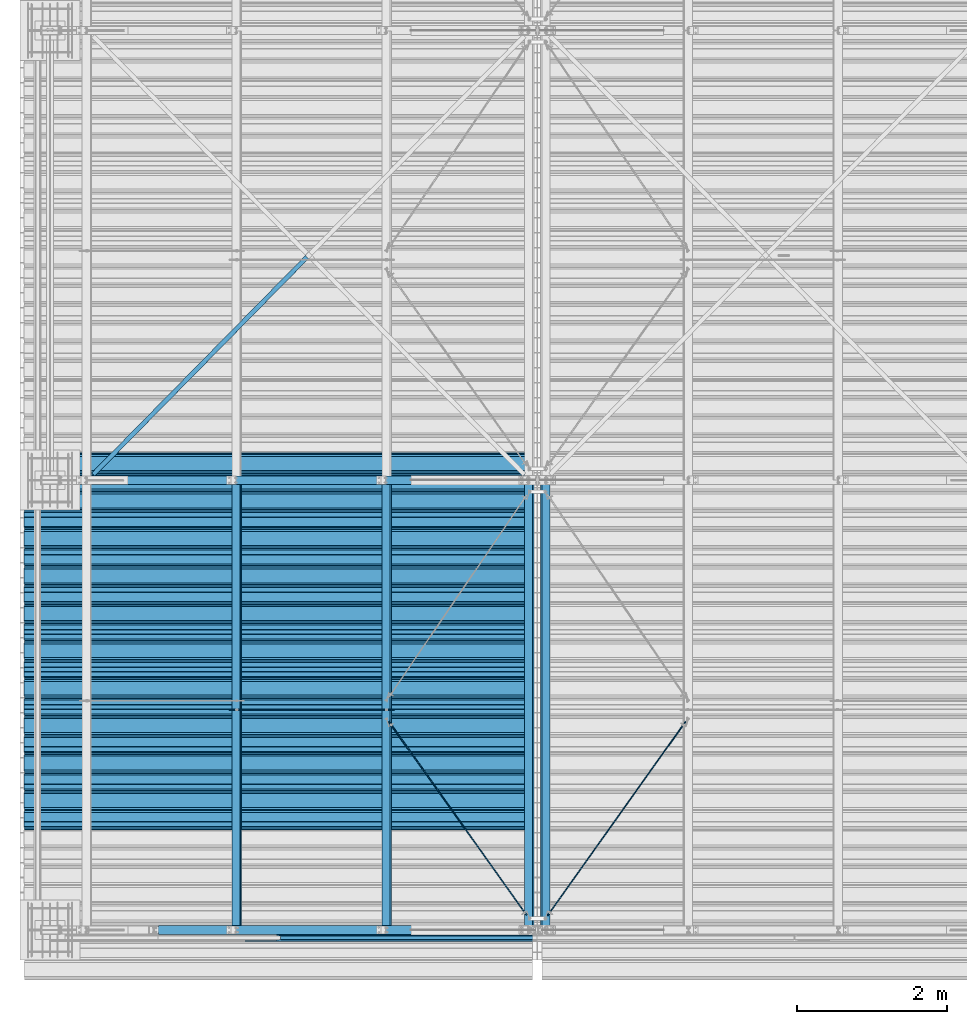
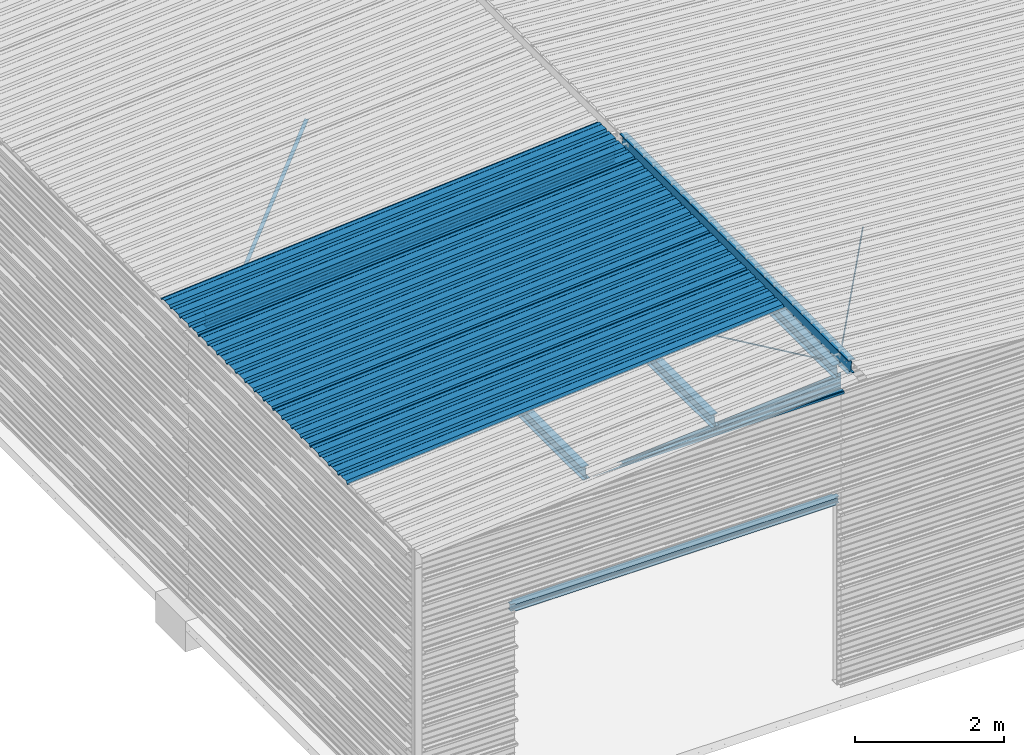
# One storey, part 6 of 70: 16 beams, 16 elements without a shape of their own.
"""IFC2X3 building model written with IfcOpenShell, lengths in millimetres."""

from ifc_helpers import new_model, si_unit, frame, origin_with_axes, origin_2d_with_axis, place, context, subcontext, project, spatial, polyline, circle, i_section, l_section, outline, extrude, boolean, clip, halfspace, material, type_object, element, aggregate, save


model = new_model("IFC2X3")

# Units and contexts
model_context = context("Model", 3, precision=1e-05, world=origin_with_axes())
body_context = subcontext(model_context, "Body", "Model", "MODEL_VIEW")
ifc_project = project(units=[si_unit("LENGTHUNIT", "METRE", prefix="MILLI"), si_unit("AREAUNIT", "SQUARE_METRE"), si_unit("VOLUMEUNIT", "CUBIC_METRE"), si_unit("MASSUNIT", "GRAM", prefix="KILO"), si_unit("TIMEUNIT", "SECOND"), si_unit("PLANEANGLEUNIT", "RADIAN"), si_unit("SOLIDANGLEUNIT", "STERADIAN"), si_unit("THERMODYNAMICTEMPERATUREUNIT", "DEGREE_CELSIUS"), si_unit("LUMINOUSINTENSITYUNIT", "LUMEN")], contexts=[model_context])

# Site, building, storey
site_placement = place(None, origin_with_axes())
site = spatial("IfcSite", under=ifc_project, at=site_placement, CompositionType="ELEMENT")
building_placement = place(site_placement, origin_with_axes())
building = spatial("IfcBuilding", under=site, at=building_placement, Name="Undefined", CompositionType="ELEMENT")
storey_placement = place(building_placement, origin_with_axes())
storey = spatial("IfcBuildingStorey", under=building, at=storey_placement, Name="Undefined", CompositionType="ELEMENT", Elevation=0.0)

# Assembly, beam
assembly_1_placement = place(storey_placement, origin_with_axes())
assembly_1 = element("IfcElementAssembly", 1, at=assembly_1_placement, inside=storey, Name="Steel Assembly", AssemblyPlace="NOTDEFINED", PredefinedType="RIGID_FRAME")
ifc_material = material(Name="STEEL/S235JR")
beam_type_1 = type_object("IfcBeamType", Name="4.40", PredefinedType="NOTDEFINED")
beam_1_placement = place(assembly_1_placement, frame((6436.39248868039, 1850.0, 5336.31760454388), z_axis=(0.0766964990376782, 0.0, -0.997054485489817), x_axis=(-0.997054485489818, 0.0, -0.0766964990376602)))
beam_1 = element("IfcBeam", 2, at=beam_1_placement, type_object=beam_type_1, material=ifc_material, ObjectType="4.40", context=body_context, shape_type="SweptSolid", body=[
    extrude(outline(polyline([(509.415161132813, 19.5000000011705), (490.584838867188, 19.5000000011705), (468.084838867188, -20.4999999988113), (406.585784912109, -20.4999999988113), (404.585784912109, -18.4999999988122), (345.414215087891, -18.4999999988122), (343.414215087891, -20.4999999988113), (281.915161132813, -20.4999999988113), (259.415161132813, 19.5000000011705), (240.584854125977, 19.5000000011705), (218.084854125977, -20.4999999988113), (156.585784912109, -20.4999999988113), (154.585784912109, -18.4999999988122), (95.4142150878906, -18.4999999988122), (93.4142150878906, -20.4999999988113), (31.9151515960693, -20.4999999988113), (9.41515254974365, 19.5000000011705), (-9.41515254974365, 19.5000000011705), (-31.9151515960693, -20.4999999988113), (-93.4142150878906, -20.4999999988113), (-95.4142150878906, -18.4999999988122), (-154.585784912109, -18.4999999988122), (-156.585784912109, -20.4999999988113), (-218.084854125977, -20.4999999988113), (-240.584854125977, 19.5000000011705), (-259.415161132813, 19.5000000011705), (-281.915161132813, -20.4999999988113), (-343.414215087891, -20.4999999988113), (-345.414215087891, -18.4999999988122), (-404.585784912109, -18.4999999988122), (-406.585784912109, -20.4999999988113), (-468.084838867188, -20.4999999988113), (-490.584838867188, 19.5000000011705), (-509.415161132813, 19.5000000011705), (-516.482360839844, 6.9361057293263), (-517.353942871094, 7.42636680720625), (-510.0, 20.5000000011705), (-490.0, 20.5000000011705), (-467.5, -19.4999999988122), (-407.0, -19.4999999988122), (-405.0, -17.4999999988131), (-345.0, -17.4999999988131), (-343.0, -19.4999999988122), (-282.5, -19.4999999988122), (-260.0, 20.5000000011705), (-240.0, 20.5000000011705), (-217.5, -19.4999999988122), (-157.0, -19.4999999988122), (-155.0, -17.4999999988131), (-95.0, -17.4999999988131), (-93.0, -19.4999999988122), (-32.5, -19.4999999988122), (-10.0, 20.5000000011705), (10.0, 20.5000000011705), (32.5, -19.4999999988122), (93.0, -19.4999999988122), (95.0, -17.4999999988131), (155.0, -17.4999999988131), (157.0, -19.4999999988122), (217.5, -19.4999999988122), (240.0, 20.5000000011705), (260.0, 20.5000000011705), (282.5, -19.4999999988122), (343.0, -19.4999999988122), (345.0, -17.4999999988131), (405.0, -17.4999999988131), (407.0, -19.4999999988122), (467.5, -19.4999999988122), (490.0, 20.5000000011705), (510.0, 20.5000000011705), (517.353942871094, 7.42636680720625), (516.482360839844, 6.9361057293263), (509.415161132813, 19.5000000011705)])), frame((6799.99999999733, 2.8421709430404e-14, 0.0), z_axis=(-1.0, 0.0, 0.0), x_axis=(0.0, -1.0, 0.0)), (0.0, 0.0, 1.0), 6800.0),
])
aggregate(assembly_1, [beam_1])

assembly_2_placement = place(storey_placement, origin_with_axes())
assembly_2 = element("IfcElementAssembly", 3, at=assembly_2_placement, inside=storey, Name="Steel Assembly", AssemblyPlace="NOTDEFINED", PredefinedType="RIGID_FRAME")
beam_2_placement = place(assembly_2_placement, frame((6436.39248868039, 2850.0, 5336.31760454388), z_axis=(0.0766964990376782, 0.0, -0.997054485489817), x_axis=(-0.997054485489818, 0.0, -0.0766964990376602)))
beam_2 = element("IfcBeam", 4, at=beam_2_placement, type_object=beam_type_1, material=ifc_material, ObjectType="4.40", context=body_context, shape_type="SweptSolid", body=[
    extrude(outline(polyline([(509.415161132813, 19.5000000011705), (490.584838867188, 19.5000000011705), (468.084838867188, -20.4999999988113), (406.585784912109, -20.4999999988113), (404.585784912109, -18.4999999988122), (345.414215087891, -18.4999999988122), (343.414215087891, -20.4999999988113), (281.915161132813, -20.4999999988113), (259.415161132813, 19.5000000011705), (240.584854125977, 19.5000000011705), (218.084854125977, -20.4999999988113), (156.585784912109, -20.4999999988113), (154.585784912109, -18.4999999988122), (95.4142150878906, -18.4999999988122), (93.4142150878906, -20.4999999988113), (31.9151515960693, -20.4999999988113), (9.41515254974365, 19.5000000011705), (-9.41515254974365, 19.5000000011705), (-31.9151515960693, -20.4999999988113), (-93.4142150878906, -20.4999999988113), (-95.4142150878906, -18.4999999988122), (-154.585784912109, -18.4999999988122), (-156.585784912109, -20.4999999988113), (-218.084854125977, -20.4999999988113), (-240.584854125977, 19.5000000011705), (-259.415161132813, 19.5000000011705), (-281.915161132813, -20.4999999988113), (-343.414215087891, -20.4999999988113), (-345.414215087891, -18.4999999988122), (-404.585784912109, -18.4999999988122), (-406.585784912109, -20.4999999988113), (-468.084838867188, -20.4999999988113), (-490.584838867188, 19.5000000011705), (-509.415161132813, 19.5000000011705), (-516.482360839844, 6.9361057293263), (-517.353942871094, 7.42636680720625), (-510.0, 20.5000000011705), (-490.0, 20.5000000011705), (-467.5, -19.4999999988122), (-407.0, -19.4999999988122), (-405.0, -17.4999999988131), (-345.0, -17.4999999988131), (-343.0, -19.4999999988122), (-282.5, -19.4999999988122), (-260.0, 20.5000000011705), (-240.0, 20.5000000011705), (-217.5, -19.4999999988122), (-157.0, -19.4999999988122), (-155.0, -17.4999999988131), (-95.0, -17.4999999988131), (-93.0, -19.4999999988122), (-32.5, -19.4999999988122), (-10.0, 20.5000000011705), (10.0, 20.5000000011705), (32.5, -19.4999999988122), (93.0, -19.4999999988122), (95.0, -17.4999999988131), (155.0, -17.4999999988131), (157.0, -19.4999999988122), (217.5, -19.4999999988122), (240.0, 20.5000000011705), (260.0, 20.5000000011705), (282.5, -19.4999999988122), (343.0, -19.4999999988122), (345.0, -17.4999999988131), (405.0, -17.4999999988131), (407.0, -19.4999999988122), (467.5, -19.4999999988122), (490.0, 20.5000000011705), (510.0, 20.5000000011705), (517.353942871094, 7.42636680720625), (516.482360839844, 6.9361057293263), (509.415161132813, 19.5000000011705)])), frame((6799.99999999733, 2.8421709430404e-14, 0.0), z_axis=(-1.0, 0.0, 0.0), x_axis=(0.0, -1.0, 0.0)), (0.0, 0.0, 1.0), 6800.0),
])
aggregate(assembly_2, [beam_2])

assembly_3_placement = place(storey_placement, origin_with_axes())
assembly_3 = element("IfcElementAssembly", 5, at=assembly_3_placement, inside=storey, Name="Steel Assembly", AssemblyPlace="NOTDEFINED", PredefinedType="RIGID_FRAME")
beam_3_placement = place(assembly_3_placement, frame((6436.39248868039, 3850.0, 5336.31760454388), z_axis=(0.0766964990376782, 0.0, -0.997054485489817), x_axis=(-0.997054485489818, 0.0, -0.0766964990376602)))
beam_3 = element("IfcBeam", 6, at=beam_3_placement, type_object=beam_type_1, material=ifc_material, ObjectType="4.40", context=body_context, shape_type="SweptSolid", body=[
    extrude(outline(polyline([(509.415161132813, 19.5000000011705), (490.584838867188, 19.5000000011705), (468.084838867188, -20.4999999988113), (406.585784912109, -20.4999999988113), (404.585784912109, -18.4999999988122), (345.414215087891, -18.4999999988122), (343.414215087891, -20.4999999988113), (281.915161132813, -20.4999999988113), (259.415161132813, 19.5000000011705), (240.584854125977, 19.5000000011705), (218.084854125977, -20.4999999988113), (156.585784912109, -20.4999999988113), (154.585784912109, -18.4999999988122), (95.4142150878906, -18.4999999988122), (93.4142150878906, -20.4999999988113), (31.9151515960693, -20.4999999988113), (9.41515254974365, 19.5000000011705), (-9.41515254974365, 19.5000000011705), (-31.9151515960693, -20.4999999988113), (-93.4142150878906, -20.4999999988113), (-95.4142150878906, -18.4999999988122), (-154.585784912109, -18.4999999988122), (-156.585784912109, -20.4999999988113), (-218.084854125977, -20.4999999988113), (-240.584854125977, 19.5000000011705), (-259.415161132813, 19.5000000011705), (-281.915161132813, -20.4999999988113), (-343.414215087891, -20.4999999988113), (-345.414215087891, -18.4999999988122), (-404.585784912109, -18.4999999988122), (-406.585784912109, -20.4999999988113), (-468.084838867188, -20.4999999988113), (-490.584838867188, 19.5000000011705), (-509.415161132813, 19.5000000011705), (-516.482360839844, 6.9361057293263), (-517.353942871094, 7.42636680720625), (-510.0, 20.5000000011705), (-490.0, 20.5000000011705), (-467.5, -19.4999999988122), (-407.0, -19.4999999988122), (-405.0, -17.4999999988131), (-345.0, -17.4999999988131), (-343.0, -19.4999999988122), (-282.5, -19.4999999988122), (-260.0, 20.5000000011705), (-240.0, 20.5000000011705), (-217.5, -19.4999999988122), (-157.0, -19.4999999988122), (-155.0, -17.4999999988131), (-95.0, -17.4999999988131), (-93.0, -19.4999999988122), (-32.5, -19.4999999988122), (-10.0, 20.5000000011705), (10.0, 20.5000000011705), (32.5, -19.4999999988122), (93.0, -19.4999999988122), (95.0, -17.4999999988131), (155.0, -17.4999999988131), (157.0, -19.4999999988122), (217.5, -19.4999999988122), (240.0, 20.5000000011705), (260.0, 20.5000000011705), (282.5, -19.4999999988122), (343.0, -19.4999999988122), (345.0, -17.4999999988131), (405.0, -17.4999999988131), (407.0, -19.4999999988122), (467.5, -19.4999999988122), (490.0, 20.5000000011705), (510.0, 20.5000000011705), (517.353942871094, 7.42636680720625), (516.482360839844, 6.9361057293263), (509.415161132813, 19.5000000011705)])), frame((6799.99999999733, 2.8421709430404e-14, 0.0), z_axis=(-1.0, 0.0, 0.0), x_axis=(0.0, -1.0, 0.0)), (0.0, 0.0, 1.0), 6800.0),
])
aggregate(assembly_3, [beam_3])

assembly_4_placement = place(storey_placement, origin_with_axes())
assembly_4 = element("IfcElementAssembly", 7, at=assembly_4_placement, inside=storey, Name="Steel Assembly", AssemblyPlace="NOTDEFINED", PredefinedType="RIGID_FRAME")
beam_4_placement = place(assembly_4_placement, frame((6436.39248868039, 4850.0, 5336.31760454388), z_axis=(0.0766964990376782, 0.0, -0.997054485489817), x_axis=(-0.997054485489818, 0.0, -0.0766964990376602)))
beam_4 = element("IfcBeam", 8, at=beam_4_placement, type_object=beam_type_1, material=ifc_material, ObjectType="4.40", context=body_context, shape_type="SweptSolid", body=[
    extrude(outline(polyline([(509.415161132813, 19.5000000011705), (490.584838867188, 19.5000000011705), (468.084838867188, -20.4999999988113), (406.585784912109, -20.4999999988113), (404.585784912109, -18.4999999988122), (345.414215087891, -18.4999999988122), (343.414215087891, -20.4999999988113), (281.915161132813, -20.4999999988113), (259.415161132813, 19.5000000011705), (240.584854125977, 19.5000000011705), (218.084854125977, -20.4999999988113), (156.585784912109, -20.4999999988113), (154.585784912109, -18.4999999988122), (95.4142150878906, -18.4999999988122), (93.4142150878906, -20.4999999988113), (31.9151515960693, -20.4999999988113), (9.41515254974365, 19.5000000011705), (-9.41515254974365, 19.5000000011705), (-31.9151515960693, -20.4999999988113), (-93.4142150878906, -20.4999999988113), (-95.4142150878906, -18.4999999988122), (-154.585784912109, -18.4999999988122), (-156.585784912109, -20.4999999988113), (-218.084854125977, -20.4999999988113), (-240.584854125977, 19.5000000011705), (-259.415161132813, 19.5000000011705), (-281.915161132813, -20.4999999988113), (-343.414215087891, -20.4999999988113), (-345.414215087891, -18.4999999988122), (-404.585784912109, -18.4999999988122), (-406.585784912109, -20.4999999988113), (-468.084838867188, -20.4999999988113), (-490.584838867188, 19.5000000011705), (-509.415161132813, 19.5000000011705), (-516.482360839844, 6.9361057293263), (-517.353942871094, 7.42636680720625), (-510.0, 20.5000000011705), (-490.0, 20.5000000011705), (-467.5, -19.4999999988122), (-407.0, -19.4999999988122), (-405.0, -17.4999999988131), (-345.0, -17.4999999988131), (-343.0, -19.4999999988122), (-282.5, -19.4999999988122), (-260.0, 20.5000000011705), (-240.0, 20.5000000011705), (-217.5, -19.4999999988122), (-157.0, -19.4999999988122), (-155.0, -17.4999999988131), (-95.0, -17.4999999988131), (-93.0, -19.4999999988122), (-32.5, -19.4999999988122), (-10.0, 20.5000000011705), (10.0, 20.5000000011705), (32.5, -19.4999999988122), (93.0, -19.4999999988122), (95.0, -17.4999999988131), (155.0, -17.4999999988131), (157.0, -19.4999999988122), (217.5, -19.4999999988122), (240.0, 20.5000000011705), (260.0, 20.5000000011705), (282.5, -19.4999999988122), (343.0, -19.4999999988122), (345.0, -17.4999999988131), (405.0, -17.4999999988131), (407.0, -19.4999999988122), (467.5, -19.4999999988122), (490.0, 20.5000000011705), (510.0, 20.5000000011705), (517.353942871094, 7.42636680720625), (516.482360839844, 6.9361057293263), (509.415161132813, 19.5000000011705)])), frame((6799.99999999733, 2.8421709430404e-14, 0.0), z_axis=(-1.0, 0.0, 0.0), x_axis=(0.0, -1.0, 0.0)), (0.0, 0.0, 1.0), 6800.0),
])
aggregate(assembly_4, [beam_4])

assembly_5_placement = place(storey_placement, origin_with_axes())
assembly_5 = element("IfcElementAssembly", 9, at=assembly_5_placement, inside=storey, Name="Steel Assembly", AssemblyPlace="NOTDEFINED", PredefinedType="RIGID_FRAME")
beam_5_placement = place(assembly_5_placement, frame((6436.39248868039, 5850.0, 5336.31760454388), z_axis=(0.0766964990376782, 0.0, -0.997054485489817), x_axis=(-0.997054485489818, 0.0, -0.0766964990376602)))
beam_5 = element("IfcBeam", 10, at=beam_5_placement, type_object=beam_type_1, material=ifc_material, ObjectType="4.40", context=body_context, shape_type="SweptSolid", body=[
    extrude(outline(polyline([(509.415161132813, 19.5000000011705), (490.584838867188, 19.5000000011705), (468.084838867188, -20.4999999988113), (406.585784912109, -20.4999999988113), (404.585784912109, -18.4999999988122), (345.414215087891, -18.4999999988122), (343.414215087891, -20.4999999988113), (281.915161132813, -20.4999999988113), (259.415161132813, 19.5000000011705), (240.584854125977, 19.5000000011705), (218.084854125977, -20.4999999988113), (156.585784912109, -20.4999999988113), (154.585784912109, -18.4999999988122), (95.4142150878906, -18.4999999988122), (93.4142150878906, -20.4999999988113), (31.9151515960693, -20.4999999988113), (9.41515254974365, 19.5000000011705), (-9.41515254974365, 19.5000000011705), (-31.9151515960693, -20.4999999988113), (-93.4142150878906, -20.4999999988113), (-95.4142150878906, -18.4999999988122), (-154.585784912109, -18.4999999988122), (-156.585784912109, -20.4999999988113), (-218.084854125977, -20.4999999988113), (-240.584854125977, 19.5000000011705), (-259.415161132813, 19.5000000011705), (-281.915161132813, -20.4999999988113), (-343.414215087891, -20.4999999988113), (-345.414215087891, -18.4999999988122), (-404.585784912109, -18.4999999988122), (-406.585784912109, -20.4999999988113), (-468.084838867188, -20.4999999988113), (-490.584838867188, 19.5000000011705), (-509.415161132813, 19.5000000011705), (-516.482360839844, 6.9361057293263), (-517.353942871094, 7.42636680720625), (-510.0, 20.5000000011705), (-490.0, 20.5000000011705), (-467.5, -19.4999999988122), (-407.0, -19.4999999988122), (-405.0, -17.4999999988131), (-345.0, -17.4999999988131), (-343.0, -19.4999999988122), (-282.5, -19.4999999988122), (-260.0, 20.5000000011705), (-240.0, 20.5000000011705), (-217.5, -19.4999999988122), (-157.0, -19.4999999988122), (-155.0, -17.4999999988131), (-95.0, -17.4999999988131), (-93.0, -19.4999999988122), (-32.5, -19.4999999988122), (-10.0, 20.5000000011705), (10.0, 20.5000000011705), (32.5, -19.4999999988122), (93.0, -19.4999999988122), (95.0, -17.4999999988131), (155.0, -17.4999999988131), (157.0, -19.4999999988122), (217.5, -19.4999999988122), (240.0, 20.5000000011705), (260.0, 20.5000000011705), (282.5, -19.4999999988122), (343.0, -19.4999999988122), (345.0, -17.4999999988131), (405.0, -17.4999999988131), (407.0, -19.4999999988122), (467.5, -19.4999999988122), (490.0, 20.5000000011705), (510.0, 20.5000000011705), (517.353942871094, 7.42636680720625), (516.482360839844, 6.9361057293263), (509.415161132813, 19.5000000011705)])), frame((6799.99999999733, 2.8421709430404e-14, 0.0), z_axis=(-1.0, 0.0, 0.0), x_axis=(0.0, -1.0, 0.0)), (0.0, 0.0, 1.0), 6800.0),
])
aggregate(assembly_5, [beam_5])

assembly_6_placement = place(storey_placement, origin_with_axes())
assembly_6 = element("IfcElementAssembly", 11, at=assembly_6_placement, inside=storey, Name="Steel Assembly", AssemblyPlace="NOTDEFINED", PredefinedType="RIGID_FRAME")
beam_type_2 = type_object("IfcBeamType", Name="400", PredefinedType="NOTDEFINED")
beam_6_placement = place(assembly_6_placement, frame((6500.0, -105.5, 5018.25), z_axis=(0.0, -1.0, 0.0), x_axis=(-1.0, 0.0, 0.0)))
beam_6 = element("IfcBeam", 12, at=beam_6_placement, type_object=beam_type_2, material=ifc_material, ObjectType="400", context=body_context, shape_type="Clipping", body=[
    clip(extrude(outline(polyline([(218.25, -24.994083404541), (214.25, -31.8999996185303), (214.25, -45.5), (199.75, -45.5), (194.25, -42.5), (188.75, -45.5), (124.25, -45.5), (114.25, -41.5), (104.25, -45.5), (24.25, -45.5), (14.25, -41.5), (4.25, -45.5), (-75.75, -45.5), (-85.75, -41.5), (-95.75, -45.5), (-160.25, -45.5), (-165.75, -42.5), (-171.25, -45.5), (-185.75, -45.5), (-185.75, -30.711540222168), (-181.75, -23.8111782073975), (-181.75, 23.311637878418), (-185.75, 30.2119998931885), (-185.75, 44.5), (-217.25, 44.5), (-217.25, 34.7999992370605), (-218.25, 34.7999992370605), (-218.25, 45.5), (-184.75, 45.5), (-184.75, 30.480884552002), (-180.75, 23.5805225372314), (-180.75, -24.0800628662109), (-184.75, -30.9804248809814), (-184.75, -44.5), (-171.504989624023, -44.5), (-165.75, -41.360912322998), (-159.995010375977, -44.5), (-95.9425811767578, -44.5), (-85.75, -40.422966003418), (-75.5574188232422, -44.5), (4.05741739273071, -44.5), (14.25, -40.422966003418), (24.4425830841064, -44.5), (104.057418823242, -44.5), (114.25, -40.422966003418), (124.442581176758, -44.5), (188.495010375977, -44.5), (194.25, -41.360912322998), (200.004989624023, -44.5), (213.25, -44.5), (213.25, -31.6313018798828), (217.25, -24.7253856658936), (217.25, 21.7253856658936), (213.25, 28.6313018798828), (213.25, 42.0), (187.25, 42.0), (187.25, 32.5499992370605), (186.25, 32.5499992370605), (186.25, 43.0), (214.25, 43.0), (214.25, 28.8999996185303), (218.25, 21.994083404541), (218.25, -24.994083404541)])), frame((6500.0, 0.0, 0.0), z_axis=(-1.0, 0.0, 0.0), x_axis=(0.0, -1.0, 0.0)), (0.0, 0.0, 1.0), 6500.0), halfspace(frame((6500.0, 418.250001003011, -45.0), z_axis=(0.0766964990376779, -0.997054485489817, 0.0), x_axis=(-0.997054485489817, -0.0766964990376779, 0.0)), False)),
])
aggregate(assembly_6, [beam_6])

assembly_7_placement = place(storey_placement, origin_with_axes())
assembly_7 = element("IfcElementAssembly", 13, at=assembly_7_placement, inside=storey, Name="Steel Assembly", AssemblyPlace="NOTDEFINED", PredefinedType="RIGID_FRAME")
beam_type_3 = type_object("IfcBeamType", Name="HEA120", PredefinedType="NOTDEFINED")
beam_7_placement = place(assembly_7_placement, frame((6499.99999986275, 0.0, 3000.00000002277), z_axis=(0.0, 0.0, -1.0), x_axis=(-1.0, 0.0, 0.0)))
beam_7 = element("IfcBeam", 14, at=beam_7_placement, type_object=beam_type_3, material=ifc_material, Name="POUTRE", ObjectType="HEA120", context=body_context, shape_type="CSG", body=[
    boolean("DIFFERENCE", boolean("DIFFERENCE", boolean("DIFFERENCE", boolean("DIFFERENCE", boolean("DIFFERENCE", boolean("DIFFERENCE", extrude(i_section(OverallWidth=120.0, OverallDepth=114.0, WebThickness=5.0, FlangeThickness=8.0, FilletRadius=12.0, at=origin_2d_with_axis()), frame((5108.49999986277, 0.0, 0.0), z_axis=(-1.0, 0.0, 0.0), x_axis=(0.0, -1.0, 0.0)), (0.0, 0.0, 1.0), 5096.0), extrude(outline(polyline([(0.0, 0.0), (69.5, 0.0), (69.5, 33.0), (0.0, 33.0), (0.0, 0.0)])), frame((2.49999986274634, -37.0, 67.0), z_axis=(0.0, 0.0, -1.0), x_axis=(1.0, 0.0, 0.0)), (0.0, 0.0, 1.0), 134.0)), extrude(outline(polyline([(0.0, 0.0), (69.5, 0.0), (69.5, 33.0), (0.0, 33.0), (0.0, 0.0)])), frame((2.49999986274634, 37.0, -67.0), z_axis=(0.0, 0.0, 1.0), x_axis=(1.0, 0.0, 0.0)), (0.0, 0.0, 1.0), 134.0)), extrude(outline(polyline([(0.0, 0.0), (69.5, 0.0), (69.5, 33.0), (0.0, 33.0), (0.0, 0.0)])), frame((5118.49999986275, 37.0, 66.9999999999932), z_axis=(0.0, 0.0, -1.0), x_axis=(-1.0, 0.0, 0.0)), (0.0, 0.0, 1.0), 134.0)), extrude(outline(polyline([(0.0, 0.0), (69.5, 0.0), (69.5, 33.0), (0.0, 33.0), (0.0, 0.0)])), frame((5118.49999986275, -37.0, -67.0000000000041), z_axis=(0.0, 0.0, 1.0), x_axis=(-1.0, 0.0, 0.0)), (0.0, 0.0, 1.0), 134.0)), halfspace(frame((5108.49999986277, 0.0, 57.0), z_axis=(-1.0, 0.0, 0.0), x_axis=(0.0, -1.0, 0.0)), True)), halfspace(frame((12.4999998627463, 0.0, 57.0), z_axis=(1.0, 0.0, 0.0), x_axis=(0.0, 1.0, 0.0)), True)),
])
aggregate(assembly_7, [beam_7])

assembly_8_placement = place(storey_placement, origin_with_axes())
assembly_8 = element("IfcElementAssembly", 15, at=assembly_8_placement, inside=storey, Name="Steel Assembly", AssemblyPlace="NOTDEFINED", PredefinedType="RIGID_FRAME")
beam_type_4 = type_object("IfcBeamType", Name="D14", PredefinedType="NOTDEFINED")
beam_8_placement = place(assembly_8_placement, frame((6356.23644817559, 199.643643002843, 5199.26622952327), z_axis=(0.0766964990376782, 0.0, -0.997054485489817), x_axis=(-0.57921819911489, 0.813953996161451, -0.0445552460088377)))
beam_8 = element("IfcBeam", 16, at=beam_8_placement, type_object=beam_type_4, material=ifc_material, Name="THREAD60MM", ObjectType="D14", context=body_context, shape_type="SweptSolid", body=[
    extrude(circle(Radius=7.0, at=origin_2d_with_axis()), frame((3167.92177719323, 1.64864048308658e-13, 0.0), z_axis=(-1.0, 0.0, 0.0), x_axis=(0.0, -1.0, 0.0)), (0.0, 0.0, 1.0), 3167.92),
])
aggregate(assembly_8, [beam_8])

assembly_9_placement = place(storey_placement, origin_with_axes())
assembly_9 = element("IfcElementAssembly", 17, at=assembly_9_placement, inside=storey, Name="Steel Assembly", AssemblyPlace="NOTDEFINED", PredefinedType="RIGID_FRAME")
beam_9_placement = place(assembly_9_placement, frame((6639.30437429255, 193.377325102948, 5199.60924318148), z_axis=(-0.0766964990376782, 0.0, -0.997054485489817), x_axis=(0.57921819911489, 0.813953996161451, -0.0445552460088378)))
beam_9 = element("IfcBeam", 18, at=beam_9_placement, type_object=beam_type_4, material=ifc_material, Name="THREAD60MM", ObjectType="D14", context=body_context, shape_type="SweptSolid", body=[
    extrude(circle(Radius=7.0, at=origin_2d_with_axis()), frame((3175.62039152653, 3.71845568968092e-14, 9.31529994748815e-13), z_axis=(-1.0, 0.0, 0.0), x_axis=(0.0, -1.0, 0.0)), (0.0, 0.0, 1.0), 3175.62),
])
aggregate(assembly_9, [beam_9])

assembly_10_placement = place(storey_placement, origin_with_axes())
assembly_10 = element("IfcElementAssembly", 19, at=assembly_10_placement, inside=storey, Name="Steel Assembly", AssemblyPlace="NOTDEFINED", PredefinedType="RIGID_FRAME")
beam_10_placement = place(assembly_10_placement, frame((4591.26883365324, 2940.00000000009, 5063.49948915789), z_axis=(0.0766964990376782, 0.0, -0.997054485489817), x_axis=(-0.997054485489818, 0.0, -0.0766964990376602)))
beam_10 = element("IfcBeam", 20, at=beam_10_placement, type_object=beam_type_4, material=ifc_material, Name="THREAD60MM", ObjectType="D14", context=body_context, shape_type="SweptSolid", body=[
    extrude(circle(Radius=7.0, at=origin_2d_with_axis()), frame((2205.90843239298, 9.09494701772928e-13, -9.40107830921147e-13), z_axis=(-1.0, 0.0, 0.0), x_axis=(0.0, -1.0, 0.0)), (0.0, 0.0, 1.0), 2205.91),
])
aggregate(assembly_10, [beam_10])

assembly_11_placement = place(storey_placement, origin_with_axes())
assembly_11 = element("IfcElementAssembly", 21, at=assembly_11_placement, inside=storey, Name="Steel Assembly", AssemblyPlace="NOTDEFINED", PredefinedType="RIGID_FRAME")
beam_type_5 = type_object("IfcBeamType", PredefinedType="NOTDEFINED")
beam_11_placement = place(assembly_11_placement, frame((3432.67434976748, 8978.26978171843, 4816.71243272344), z_axis=(0.0766964990376782, 0.0, -0.997054485489817), x_axis=(-0.700122412215615, -0.711988894219269, -0.0538555700165858)))
beam_11 = element("IfcBeam", 22, at=beam_11_placement, type_object=beam_type_5, material=ifc_material, Name="POUTRE", context=body_context, shape_type="Clipping", body=[
    clip(extrude(l_section(Depth=60.0, Width=60.0, Thickness=6.0, FilletRadius=8.0, EdgeRadius=4.0, at=origin_2d_with_axis()), frame((4076.19287825594, 1.74297542815177e-12, 9.09494701772928e-13), z_axis=(-1.0, 0.0, 0.0), x_axis=(0.0, -1.0, 0.0)), (0.0, 0.0, 1.0), 4136.91), halfspace(frame((3.45844966596633, -29.9999999936672, -1.08098811324453e-06), z_axis=(1.0, 0.0, 0.0), x_axis=(0.0, 0.0, 1.0)), True)),
])
aggregate(assembly_11, [beam_11])

assembly_12_placement = place(storey_placement, origin_with_axes())
assembly_12 = element("IfcElementAssembly", 23, at=assembly_12_placement, inside=storey, Name="Steel Assembly", AssemblyPlace="NOTDEFINED", PredefinedType="RIGID_FRAME")
beam_type_6 = type_object("IfcBeamType", Name="IPE220", PredefinedType="NOTDEFINED")
beam_12_placement = place(assembly_12_placement, frame((6608.4366148552, -149.999999999999, 5201.98368623935), z_axis=(0.0766964990376782, 0.0, 0.997054485489817), x_axis=(0.0, 1.0, 0.0)))
beam_12 = element("IfcBeam", 24, at=beam_12_placement, type_object=beam_type_6, material=ifc_material, ObjectType="IPE220", context=body_context, shape_type="Clipping", body=[
    clip(extrude(i_section(OverallWidth=110.0, OverallDepth=220.0, WebThickness=5.900000095, FlangeThickness=9.199999809, FilletRadius=12.0, at=origin_2d_with_axis()), frame((6144.99999999991, 0.0, 0.0), z_axis=(-1.0, 0.0, 0.0), x_axis=(0.0, -1.0, 0.0)), (0.0, 0.0, 1.0), 6145.0), halfspace(frame((6144.99999999991, 0.0, 0.0), z_axis=(1.0, 0.0, 0.0), x_axis=(0.0, -1.0, 0.0)), False)),
])
aggregate(assembly_12, [beam_12])

assembly_13_placement = place(storey_placement, origin_with_axes())
assembly_13 = element("IfcElementAssembly", 25, at=assembly_13_placement, inside=storey, Name="Steel Assembly", AssemblyPlace="NOTDEFINED", PredefinedType="RIGID_FRAME")
beam_13_placement = place(assembly_13_placement, frame((6391.56338514143, 5999.99999999999, 5201.98368622305), z_axis=(-0.0766964990376602, 0.0, 0.997054485489818), x_axis=(0.0, -1.0, 0.0)))
beam_13 = element("IfcBeam", 26, at=beam_13_placement, type_object=beam_type_6, material=ifc_material, ObjectType="IPE220", context=body_context, shape_type="Clipping", body=[
    clip(extrude(i_section(OverallWidth=110.0, OverallDepth=220.0, WebThickness=5.900000095, FlangeThickness=9.199999809, FilletRadius=12.0, at=origin_2d_with_axis()), frame((6150.0000000001, 0.0, 0.0), z_axis=(-1.0, 0.0, 0.0), x_axis=(0.0, -1.0, 0.0)), (0.0, 0.0, 1.0), 6145.0), halfspace(frame((4.99999999999636, 7.09405867382884e-11, -1.79170456249267e-10), z_axis=(1.0, 0.0, 0.0), x_axis=(0.0, -1.0, 0.0)), True)),
])
aggregate(assembly_13, [beam_13])

assembly_14_placement = place(storey_placement, origin_with_axes())
assembly_14 = element("IfcElementAssembly", 27, at=assembly_14_placement, inside=storey, Name="Steel Assembly", AssemblyPlace="NOTDEFINED", PredefinedType="RIGID_FRAME")
beam_14_placement = place(assembly_14_placement, frame((4491.56338512995, 5999.99999999999, 5055.82983991939), z_axis=(-0.0766964990376602, 0.0, 0.997054485489818), x_axis=(0.0, -1.0, 0.0)))
beam_14 = element("IfcBeam", 28, at=beam_14_placement, type_object=beam_type_6, material=ifc_material, ObjectType="IPE220", context=body_context, shape_type="Clipping", body=[
    clip(extrude(i_section(OverallWidth=110.0, OverallDepth=220.0, WebThickness=5.900000095, FlangeThickness=9.199999809, FilletRadius=12.0, at=origin_2d_with_axis()), frame((6150.0000000001, 0.0, 0.0), z_axis=(-1.0, 0.0, 0.0), x_axis=(0.0, -1.0, 0.0)), (0.0, 0.0, 1.0), 6145.0), halfspace(frame((4.99999999999636, 7.09405867382884e-11, -1.79170456249267e-10), z_axis=(1.0, 0.0, 0.0), x_axis=(0.0, -1.0, 0.0)), True)),
])
aggregate(assembly_14, [beam_14])

assembly_15_placement = place(storey_placement, origin_with_axes())
assembly_15 = element("IfcElementAssembly", 29, at=assembly_15_placement, inside=storey, Name="Steel Assembly", AssemblyPlace="NOTDEFINED", PredefinedType="RIGID_FRAME")
beam_15_placement = place(assembly_15_placement, frame((2491.56338511787, 5999.99999999999, 4901.98368591554), z_axis=(-0.0766964990376602, 0.0, 0.997054485489818), x_axis=(0.0, -1.0, 0.0)))
beam_15 = element("IfcBeam", 30, at=beam_15_placement, type_object=beam_type_6, material=ifc_material, ObjectType="IPE220", context=body_context, shape_type="Clipping", body=[
    clip(extrude(i_section(OverallWidth=110.0, OverallDepth=220.0, WebThickness=5.900000095, FlangeThickness=9.199999809, FilletRadius=12.0, at=origin_2d_with_axis()), frame((6150.0000000001, 0.0, 0.0), z_axis=(-1.0, 0.0, 0.0), x_axis=(0.0, -1.0, 0.0)), (0.0, 0.0, 1.0), 6145.0), halfspace(frame((4.99999999999636, 7.09405867382884e-11, -1.79170456249267e-10), z_axis=(1.0, 0.0, 0.0), x_axis=(0.0, -1.0, 0.0)), True)),
])
aggregate(assembly_15, [beam_15])

assembly_16_placement = place(storey_placement, origin_with_axes())
assembly_16 = element("IfcElementAssembly", 31, at=assembly_16_placement, inside=storey, Name="Steel Assembly", AssemblyPlace="NOTDEFINED", PredefinedType="RIGID_FRAME")
beam_16_placement = place(assembly_16_placement, frame((8.43661487722628, 6000.0, 4490.32400659478), z_axis=(-0.0766964990376602, 0.0, 0.997054485489818), x_axis=(0.997054485489816, 0.0, 0.0766964990376847)))
beam_16 = element("IfcBeam", 32, at=beam_16_placement, type_object=beam_type_6, material=ifc_material, Name="POUTRE", ObjectType="IPE220", context=body_context, shape_type="Clipping", body=[
    clip(clip(extrude(i_section(OverallWidth=110.0, OverallDepth=220.0, WebThickness=5.900000095, FlangeThickness=9.199999809, FilletRadius=12.0, at=origin_2d_with_axis()), frame((6512.78885803273, 3.63797880709171e-12, 0.0), z_axis=(-1.0, 0.0, 0.0), x_axis=(0.0, -1.0, 0.0)), (0.0, 0.0, 1.0), 6402.94), halfspace(frame((6504.24658470657, 3.63797880709171e-12, 111.150446985645), z_axis=(-0.997054485489817, 0.0, 0.0766964990376713), x_axis=(0.0, -1.0, 0.0)), True)), halfspace(frame((118.475742245822, 3.63797880709171e-12, -110.000000009088), z_axis=(0.997054485489817, 0.0, -0.0766964990376783), x_axis=(0.0, -1.0, 0.0)), True)),
])
aggregate(assembly_16, [beam_16])

save(model, "model.ifc")
